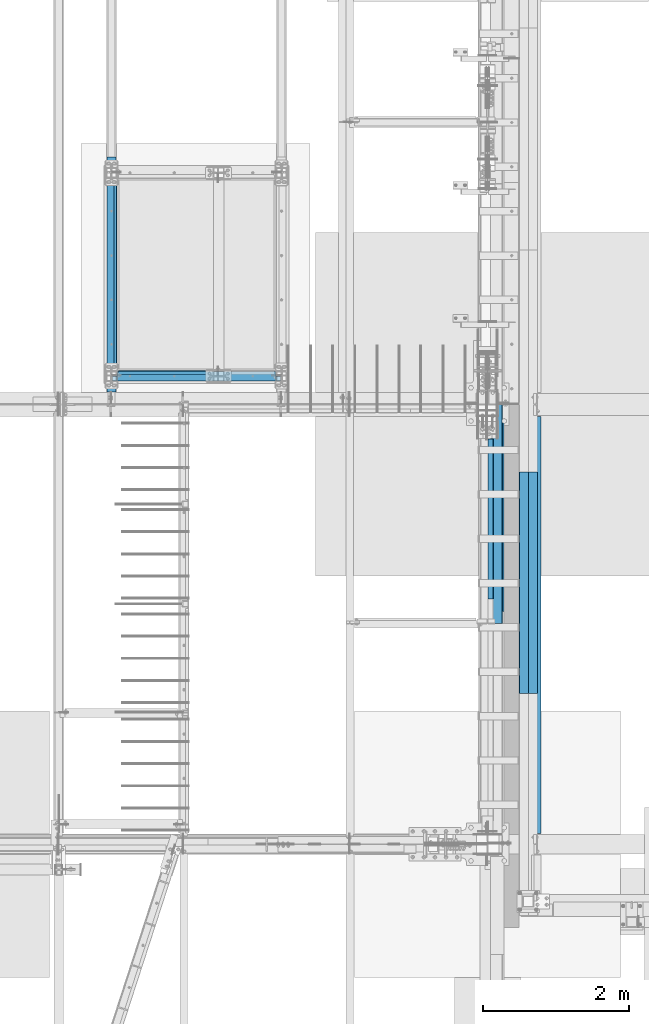
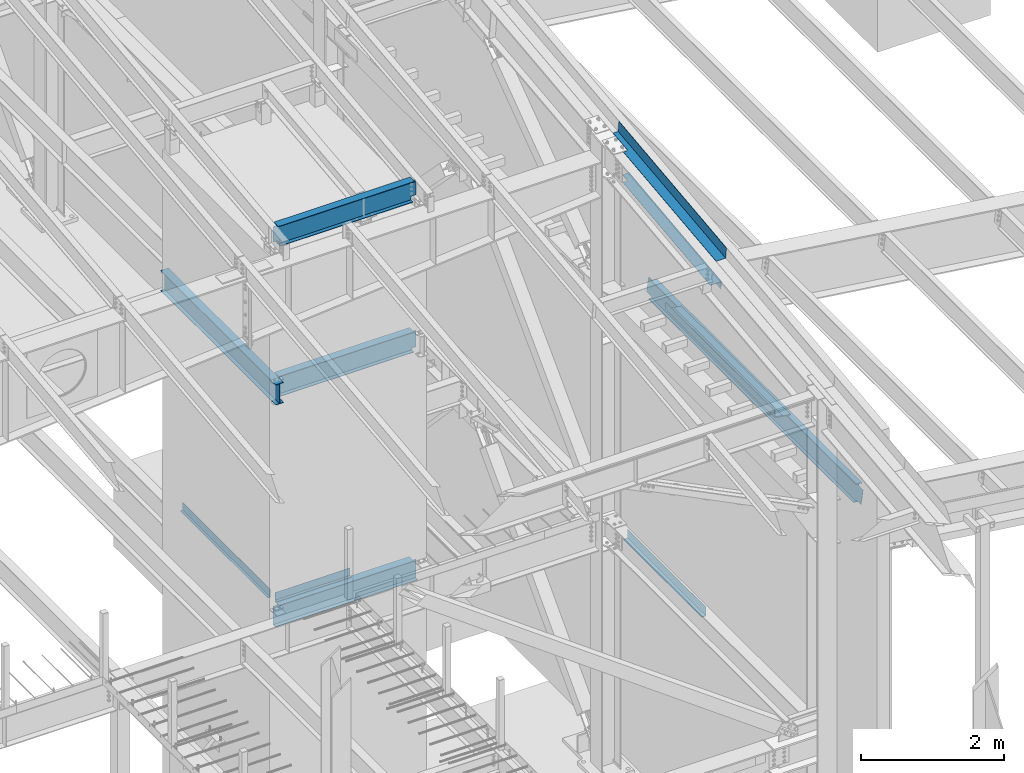
# One storey, part 721 of 1179: 12 beams, 10 elements without a shape of their own.
"""IFC2X3 building model written with IfcOpenShell, lengths in millimetres."""

from ifc_helpers import new_model, si_unit, frame, origin_with_axes, place, context, subcontext, project, spatial, faceted_brep, material, type_object, element, aggregate, save


model = new_model("IFC2X3")

# Units and contexts
model_context = context("Model", 3, precision=1e-05, world=origin_with_axes())
body_context = subcontext(model_context, "Body", "Model", "MODEL_VIEW")
ifc_project = project(units=[si_unit("LENGTHUNIT", "METRE", prefix="MILLI"), si_unit("AREAUNIT", "SQUARE_METRE"), si_unit("VOLUMEUNIT", "CUBIC_METRE"), si_unit("MASSUNIT", "GRAM", prefix="KILO"), si_unit("TIMEUNIT", "SECOND"), si_unit("PLANEANGLEUNIT", "RADIAN"), si_unit("SOLIDANGLEUNIT", "STERADIAN"), si_unit("THERMODYNAMICTEMPERATUREUNIT", "DEGREE_CELSIUS"), si_unit("LUMINOUSINTENSITYUNIT", "LUMEN")], contexts=[model_context])

# Site, building, storey
site_placement = place(None, origin_with_axes())
site = spatial("IfcSite", under=ifc_project, at=site_placement, CompositionType="ELEMENT")
building_placement = place(site_placement, origin_with_axes())
building = spatial("IfcBuilding", under=site, at=building_placement, Name="Undefined", CompositionType="ELEMENT")
storey_placement = place(building_placement, origin_with_axes())
storey = spatial("IfcBuildingStorey", under=building, at=storey_placement, Name="Undefined", CompositionType="ELEMENT", Elevation=0.0)

# Assembly, beam
assembly_1_placement = place(storey_placement, origin_with_axes())
assembly_1 = element("IfcElementAssembly", 1, at=assembly_1_placement, inside=storey, Name="BEAM", AssemblyPlace="NOTDEFINED", PredefinedType="RIGID_FRAME")
ifc_material_1 = material(Name="STEEL/A36")
beam_type_1 = type_object("IfcBeamType", PredefinedType="NOTDEFINED")
beam_1_placement = place(assembly_1_placement, frame((19837.4000030518, 11941.1750007629, 4235.45000610352), z_axis=(1.0, 0.0, 0.0), x_axis=(0.0, 0.0, -1.0)))
beam_1 = element("IfcBeam", 2, at=beam_1_placement, type_object=beam_type_1, material=ifc_material_1, Name="BENT_PLATE", context=body_context, shape_type="Brep", body=[
    faceted_brep([(0.0, -3.17499999999927, -603.25), (0.0, -3.17499999999927, 603.25), (0.0, 3.17499999999927, 603.25), (0.0, 3.17499999999927, -603.25), (133.350006103517, 3.17499999999927, 603.25), (133.350006103517, 3.17499999999927, -603.25), (127.000006103516, -3.17499999999927, -603.25), (127.000006103516, -3.17499999999927, 603.25), (133.350006103517, -47.6250007629405, 603.25), (133.350006103517, -47.6250007629405, -603.25), (127.000006103516, -47.6250007629405, 603.25), (127.000006103516, -47.6250007629405, -603.25)], [[[0, 1, 2, 3]], [[3, 2, 4, 5]], [[1, 0, 6, 7]], [[5, 4, 8, 9]], [[4, 2, 1, 7, 10, 8]], [[7, 6, 11, 10]], [[6, 0, 3, 5, 9, 11]], [[10, 11, 9, 8]]]),
])

assembly_2_placement = place(storey_placement, origin_with_axes())
assembly_2 = element("IfcElementAssembly", 3, at=assembly_2_placement, inside=storey, Name="BEAM", AssemblyPlace="NOTDEFINED", PredefinedType="RIGID_FRAME")
ifc_material_2 = material(Name="STEEL/A992")
beam_type_2 = type_object("IfcBeamType", Name="W14X22", PredefinedType="NOTDEFINED")
beam_2_placement = place(assembly_2_placement, frame((19138.9, 11868.1499999452, 10406.1649228246), z_axis=(0.0, 0.0, 1.0), x_axis=(1.0, 0.0, 0.0)))
beam_2 = element("IfcBeam", 4, at=beam_2_placement, type_object=beam_type_2, material=ifc_material_2, Name="BEAM", ObjectType="W14X22", context=body_context, shape_type="Brep", body=[
    faceted_brep([(2244.725, -3.17499999999927, -166.6875), (2244.725, -63.5, -166.6875), (2244.725, -63.5, -174.625), (2244.725, 63.5, -174.625), (2244.725, 63.5, -166.6875), (2244.725, 3.17499999999927, -166.6875), (2244.725, 3.17499999999927, -123.824999806495), (2244.725, -3.17499999999927, -123.824999806495), (2245.69172992259, 3.17499999999927, -118.964920288448), (2245.69172992259, -3.17499999999927, -118.964920288448), (2248.44474382306, 3.17499999999927, -114.844743820295), (2248.44474382306, -3.17499999999927, -114.844743820295), (2252.56492029122, 3.17499999999927, -112.091729919817), (2252.56492029122, -3.17499999999927, -112.091729919817), (2257.42499980926, 3.17499999999927, -111.12499999723), (2257.42499980926, -3.17499999999927, -111.12499999723), (2320.925, -3.17499999999927, -111.12499999723), (2320.925, 3.17499999999927, -111.12499999723), (66.6749999999993, 3.17499999999927, 166.6875), (66.6749999999993, 63.5, 166.6875), (2270.125, 63.5, 166.6875), (2270.125, 3.17499999999927, 166.6875), (92.0750000000007, -3.17499999999927, -123.824999806491), (92.0750000000007, 3.17499999999927, -123.824999806491), (92.0750000000007, 3.17499999999927, -166.6875), (92.0750000000007, 63.5, -166.6875), (92.0750000000007, 63.5, -174.625), (92.0750000000007, -63.5, -174.625), (92.0750000000007, -63.5, -166.6875), (92.0750000000007, -3.17499999999927, -166.6875), (91.1082700774132, -3.17499999999927, -118.964920288445), (91.1082700774132, 3.17499999999927, -118.964920288445), (88.3552561769357, -3.17499999999927, -114.844743820291), (88.3552561769357, 3.17499999999927, -114.844743820291), (84.235079708782, -3.17499999999927, -112.091729919814), (84.235079708782, 3.17499999999927, -112.091729919814), (79.3750001907356, -3.17499999999927, -111.124999997226), (79.3750001907356, 3.17499999999927, -111.124999997226), (15.875, -3.17499999999927, -111.124999997226), (15.875, 3.17499999999927, -111.124999997226), (15.875, -3.17499999999927, 149.225000002774), (15.875, 3.17499999999927, 149.225000002774), (53.9750001907341, -3.17499999999927, 149.225000002774), (53.9750001907341, 3.17499999999927, 149.225000002774), (58.8350797087805, -3.17499999999927, 150.191729925362), (58.8350797087805, 3.17499999999927, 150.191729925362), (62.9552561769342, -3.17499999999927, 152.944743825839), (62.9552561769342, 3.17499999999927, 152.944743825839), (65.7082700774117, -3.17499999999927, 157.064920293993), (65.7082700774117, 3.17499999999927, 157.064920293993), (66.6749999999993, -3.17499999999927, 161.924999812039), (66.6749999999993, 3.17499999999927, 161.924999812039), (66.6749999999993, -63.5, 174.625), (66.6749999999993, 63.5, 174.625), (66.6749999999993, -3.17499999999927, 166.6875), (66.6749999999993, -63.5, 166.6875), (2270.125, -3.17499999999927, 166.6875), (2270.125, -63.5, 166.6875), (2270.125, -63.5, 174.625), (2270.125, 63.5, 174.625), (2270.125, -3.17499999999927, 161.924999812036), (2270.125, 3.17499999999927, 161.924999812036), (2271.09172992259, -3.17499999999927, 157.064920293989), (2271.09172992259, 3.17499999999927, 157.064920293989), (2273.84474382307, -3.17499999999927, 152.944743825836), (2273.84474382307, 3.17499999999927, 152.944743825836), (2277.96492029122, -3.17499999999927, 150.191729925358), (2277.96492029122, 3.17499999999927, 150.191729925358), (2282.82499980927, -3.17499999999927, 149.225000002771), (2282.82499980927, 3.17499999999927, 149.225000002771), (2320.925, -3.17499999999927, 149.225000002771), (2320.925, 3.17499999999927, 149.225000002771)], [[[0, 1, 2, 3, 4, 5, 6, 7]], [[7, 6, 8, 9]], [[9, 8, 10, 11]], [[11, 10, 12, 13]], [[13, 12, 14, 15]], [[16, 15, 14, 17]], [[18, 19, 20, 21]], [[22, 23, 24, 25, 26, 27, 28, 29]], [[30, 31, 23, 22]], [[32, 33, 31, 30]], [[34, 35, 33, 32]], [[36, 37, 35, 34]], [[38, 39, 37, 36]], [[40, 41, 39, 38]], [[42, 43, 41, 40]], [[44, 45, 43, 42]], [[46, 47, 45, 44]], [[48, 49, 47, 46]], [[50, 51, 49, 48]], [[52, 53, 19, 18, 51, 50, 54, 55]], [[55, 54, 56, 57]], [[52, 55, 57, 58]], [[53, 52, 58, 59]], [[19, 53, 59, 20]], [[58, 57, 56, 60, 61, 21, 20, 59]], [[62, 63, 61, 60]], [[64, 65, 63, 62]], [[66, 67, 65, 64]], [[68, 69, 67, 66]], [[70, 71, 69, 68]], [[71, 70, 16, 17]], [[12, 10, 8, 6, 5, 24, 23, 31, 33, 35, 37, 39, 41, 43, 45, 47, 49, 51, 18, 21, 61, 63, 65, 67, 69, 71, 17, 14]], [[25, 24, 5, 4]], [[26, 25, 4, 3]], [[27, 26, 3, 2]], [[28, 27, 2, 1]], [[29, 28, 1, 0]], [[70, 68, 66, 64, 62, 60, 56, 54, 50, 48, 46, 44, 42, 40, 38, 36, 34, 32, 30, 22, 29, 0, 7, 9, 11, 13, 15, 16]]]),
])
aggregate(assembly_2, [beam_2])

assembly_3_placement = place(storey_placement, origin_with_axes())
assembly_3 = element("IfcElementAssembly", 5, at=assembly_3_placement, inside=storey, Name="BEAM", AssemblyPlace="NOTDEFINED", PredefinedType="RIGID_FRAME")
beam_3_placement = place(assembly_3_placement, frame((19138.9, 11652.2500015259, 7839.075), z_axis=(0.0, 0.0, 1.0), x_axis=(0.0, 1.0, 0.0)))
beam_3 = element("IfcBeam", 6, at=beam_3_placement, type_object=beam_type_2, material=ifc_material_2, Name="BEAM", ObjectType="W14X22", context=body_context, shape_type="Brep", body=[
    faceted_brep([(0.0, 63.5, -174.625), (0.0, 63.5, -166.6875), (3225.79999694824, 63.5, -166.6875), (3225.79999694824, 63.5, -174.625), (-1.21872290037572e-10, 3.17500000000018, -166.687500000036), (3225.79999694824, 3.17499999999927, -166.6875), (1.20053300634027e-10, 3.17500000000018, 166.687500000036), (3225.79999694824, 3.17499999999927, 166.6875), (0.0, 63.5, 166.6875), (3225.79999694824, 63.5, 166.6875), (0.0, 63.5, 174.625), (3225.79999694824, 63.5, 174.625), (0.0, -63.5, 174.625), (3225.79999694824, -63.5, 174.625), (0.0, -63.5, 166.6875), (3225.79999694824, -63.5, 166.6875), (1.20053300634027e-10, -3.17500000000018, 166.687500000036), (3225.79999694824, -3.17499999999927, 166.6875), (-1.21872290037572e-10, -3.17500000000018, -166.687500000036), (3225.79999694824, -3.17499999999927, -166.6875), (0.0, -63.5, -166.6875), (3225.79999694824, -63.5, -166.6875), (0.0, -63.5, -174.625), (3225.79999694824, -63.5, -174.625)], [[[0, 1, 2, 3]], [[1, 4, 5, 2]], [[4, 6, 7, 5]], [[6, 8, 9, 7]], [[8, 10, 11, 9]], [[10, 12, 13, 11]], [[12, 14, 15, 13]], [[14, 16, 17, 15]], [[16, 18, 19, 17]], [[18, 20, 21, 19]], [[20, 22, 23, 21]], [[22, 0, 3, 23]], [[5, 7, 9, 11, 13, 15, 17, 19, 21, 23, 3, 2]], [[22, 20, 18, 16, 14, 12, 10, 8, 6, 4, 1, 0]]]),
])
aggregate(assembly_3, [beam_3])

assembly_4_placement = place(storey_placement, origin_with_axes())
assembly_4 = element("IfcElementAssembly", 7, at=assembly_4_placement, inside=storey, Name="BEAM", AssemblyPlace="NOTDEFINED", PredefinedType="RIGID_FRAME")
beam_4_placement = place(assembly_4_placement, frame((19138.9, 11868.15, 7839.075), z_axis=(0.0, 0.0, 1.0), x_axis=(1.0, 0.0, 0.0)))
beam_4 = element("IfcBeam", 8, at=beam_4_placement, type_object=beam_type_2, material=ifc_material_2, Name="BEAM", ObjectType="W14X22", context=body_context, shape_type="Brep", body=[
    faceted_brep([(2257.42499999999, -3.17499999999927, -166.6875), (2257.42499999999, -63.5, -166.6875), (2257.42499999999, -63.5, -174.625), (2257.42499999999, 63.5, -174.625), (2257.42499999999, 63.5, -166.6875), (2257.42499999999, 3.17499999999927, -166.6875), (2257.42499999999, 3.17499999999927, -155.574999809265), (2257.42499999999, -3.17499999999927, -155.574999809265), (2258.39172992258, 3.17499999999927, -150.71492029122), (2258.39172992258, -3.17499999999927, -150.71492029122), (2261.14474382306, 3.17499999999927, -146.594743823066), (2261.14474382306, -3.17499999999927, -146.594743823066), (2265.26492029121, 3.17499999999927, -143.841729922588), (2265.26492029121, -3.17499999999927, -143.841729922588), (2270.12499980926, 3.17499999999927, -142.875), (2270.12499980926, -3.17499999999927, -142.875), (2320.925, -3.17499999999927, -142.875), (2320.925, 3.17499999999927, -142.875), (76.2000000000007, 3.17499999999927, 166.6875), (76.2000000000007, 63.5, 166.6875), (2260.59999999999, 63.5, 166.6875), (2260.59999999999, 3.17499999999927, 166.6875), (79.375, -3.17499999999927, -155.574999809265), (79.375, 3.17499999999927, -155.574999809265), (79.375, 3.17499999999927, -166.6875), (79.375, 63.5, -166.6875), (79.375, 63.5, -174.625), (79.375, -63.5, -174.625), (79.375, -63.5, -166.6875), (79.375, -3.17499999999927, -166.6875), (78.4082700774125, -3.17499999999927, -150.71492029122), (78.4082700774125, 3.17499999999927, -150.71492029122), (75.6552561769349, -3.17499999999927, -146.594743823066), (75.6552561769349, 3.17499999999927, -146.594743823066), (71.5350797087813, -3.17499999999927, -143.841729922588), (71.5350797087813, 3.17499999999927, -143.841729922588), (66.6750001907349, -3.17499999999927, -142.875), (66.6750001907349, 3.17499999999927, -142.875), (15.8749999999964, -3.17499999999927, -142.875), (15.8749999999964, 3.17499999999927, -142.875), (15.8750000000018, -3.17500000000291, 142.874999999998), (15.8750000000018, 3.17500000000291, 142.874999999998), (63.5, -3.17499999993015, 142.874999807531), (63.5, 3.1750000039101, 142.874999807529), (68.360079708782, -3.17499999999927, 143.841729922588), (68.360079708782, 3.17499999999927, 143.841729922588), (72.4802561769357, -3.17499999999927, 146.594743823066), (72.4802561769357, 3.17499999999927, 146.594743823066), (75.2332700774132, -3.17499999999927, 150.71492029122), (75.2332700774132, 3.17499999999927, 150.71492029122), (76.2000000000007, -3.17499999999927, 155.574999809265), (76.2000000000007, 3.17499999999927, 155.574999809265), (76.2000000000007, -63.5, 174.625), (76.2000000000007, 63.5, 174.625), (76.2000000000007, -3.17499999999927, 166.6875), (76.2000000000007, -63.5, 166.6875), (2260.59999999999, -3.17499999999927, 166.6875), (2260.59999999999, -63.5, 166.6875), (2260.59999999999, -63.5, 174.625), (2260.59999999999, 63.5, 174.625), (2260.59999999999, -3.17499999999927, 155.574999809265), (2260.59999999999, 3.17499999999927, 155.574999809265), (2261.56672992258, -3.17499999999927, 150.71492029122), (2261.56672992258, 3.17499999999927, 150.71492029122), (2264.31974382306, -3.17499999999927, 146.594743823066), (2264.31974382306, 3.17499999999927, 146.594743823066), (2268.43992029121, -3.17499999999927, 143.841729922588), (2268.43992029121, 3.17499999999927, 143.841729922588), (2273.29999980926, -3.17499999999927, 142.875), (2273.29999980926, 3.17499999999927, 142.875), (2320.925, -3.17499999999927, 142.875), (2320.925, 3.17499999999927, 142.875)], [[[0, 1, 2, 3, 4, 5, 6, 7]], [[7, 6, 8, 9]], [[9, 8, 10, 11]], [[11, 10, 12, 13]], [[13, 12, 14, 15]], [[16, 15, 14, 17]], [[18, 19, 20, 21]], [[22, 23, 24, 25, 26, 27, 28, 29]], [[30, 31, 23, 22]], [[32, 33, 31, 30]], [[34, 35, 33, 32]], [[36, 37, 35, 34]], [[38, 39, 37, 36]], [[40, 41, 39, 38]], [[42, 43, 41, 40]], [[44, 45, 43, 42]], [[46, 47, 45, 44]], [[48, 49, 47, 46]], [[50, 51, 49, 48]], [[52, 53, 19, 18, 51, 50, 54, 55]], [[55, 54, 56, 57]], [[52, 55, 57, 58]], [[53, 52, 58, 59]], [[19, 53, 59, 20]], [[58, 57, 56, 60, 61, 21, 20, 59]], [[62, 63, 61, 60]], [[64, 65, 63, 62]], [[66, 67, 65, 64]], [[68, 69, 67, 66]], [[70, 71, 69, 68]], [[71, 70, 16, 17]], [[12, 10, 8, 6, 5, 24, 23, 31, 33, 35, 37, 39, 41, 43, 45, 47, 49, 51, 18, 21, 61, 63, 65, 67, 69, 71, 17, 14]], [[25, 24, 5, 4]], [[26, 25, 4, 3]], [[27, 26, 3, 2]], [[28, 27, 2, 1]], [[29, 28, 1, 0]], [[70, 68, 66, 64, 62, 60, 56, 54, 50, 48, 46, 44, 42, 40, 38, 36, 34, 32, 30, 22, 29, 0, 7, 9, 11, 13, 15, 16]]]),
])
aggregate(assembly_4, [beam_4])

# Beam
beam_5_placement = place(assembly_1_placement, frame((19138.9, 11868.15, 3927.475), z_axis=(0.0, 0.0, 1.0), x_axis=(1.0, 0.0, 0.0)))
beam_5 = element("IfcBeam", 9, at=beam_5_placement, type_object=beam_type_2, material=ifc_material_2, Name="BEAM", ObjectType="W14X22", context=body_context, shape_type="Brep", body=[
    faceted_brep([(2254.25, -63.5, 174.625), (2254.25, -63.5, 166.6875), (2254.25, -3.17499999999927, 166.6875), (2254.25, -3.17499999999927, 155.574999809265), (2254.25, 3.17495510407934, 155.574999809265), (2254.25, 3.17499999999927, 166.6875), (2254.25, 63.5, 166.6875), (2254.25, 63.5, 174.625), (2255.21672992259, -3.17499999999927, 150.71492029122), (2255.21672992259, 3.17495876243083, 150.71492029122), (2257.96974382307, -3.17499999999927, 146.594743823066), (2257.96974382307, 3.17496186523749, 146.594743823066), (2262.08992029122, -3.17499999999927, 143.841729922588), (2262.08992029122, 3.17496394012414, 143.841729922588), (2266.94999980927, -3.17499999999927, 142.875), (2266.94999980927, 3.17496467120691, 142.875), (2320.925, -3.17499999999927, 142.875), (2320.925, 3.17499999999927, 142.875), (82.5499999999993, -63.5, 174.625), (82.5499999999993, 63.5, 174.625), (82.5499999999993, 63.5, 166.6875), (82.5499999999993, 3.17500000000291, 166.6875), (82.5499999999993, 3.17496616959397, 155.574999809263), (82.5499999999993, -3.17500000000291, 155.574999809263), (82.5499999999993, -3.17500000000291, 166.6875), (82.5499999999993, -63.5, 166.6875), (81.5832700774117, 3.17496981359, 150.714920291217), (81.5832700774117, -3.17500000000291, 150.714920291217), (78.8302561769342, 3.17497290281608, 146.594743823063), (78.8302561769342, -3.17500000000291, 146.594743823063), (74.7100797087805, 3.17497496696888, 143.841729922586), (74.7100797087805, -3.17500000000291, 143.841729922586), (69.8500001907341, 3.17497569180705, 142.874999999998), (69.8500001907341, -3.17500000000291, 142.874999999998), (15.8750000000018, 3.17500000000291, 142.874999999998), (15.8750000000018, -3.17500000000291, 142.874999999998), (15.8750000000018, 3.17500000000291, -166.6875), (15.8750000000018, 3.17549991607666, -174.625), (15.8750000000018, -63.5, -174.625), (15.8750000000018, -63.5, -166.6875), (15.8750000000018, -3.17500000000291, -166.6875), (142.875000000002, 3.17549991607666, -166.6875), (142.875000000002, 3.17549991607666, -174.625), (142.875000000002, 63.5, -166.6875), (142.875000000002, 63.5, -174.625), (2193.92499999986, 3.17502914962461, -166.6875), (2193.925, 63.5, -166.6875), (2193.925, 63.5, -174.625), (2193.925, 3.17561880122958, -174.625), (2320.925, 3.17499999999927, -166.6875), (2320.925, 3.17561880122958, -174.625), (2320.925, -63.5, -174.625), (2320.925, -63.5, -166.6875), (2320.925, -3.17499999999927, -166.6875)], [[[0, 1, 2, 3, 4, 5, 6, 7]], [[8, 9, 4, 3]], [[10, 11, 9, 8]], [[12, 13, 11, 10]], [[14, 15, 13, 12]], [[16, 17, 15, 14]], [[18, 19, 20, 21, 22, 23, 24, 25]], [[23, 22, 26, 27]], [[27, 26, 28, 29]], [[29, 28, 30, 31]], [[31, 30, 32, 33]], [[33, 32, 34, 35]], [[36, 37, 38, 39, 40, 35, 34]], [[41, 42, 37, 36]], [[43, 44, 42, 41]], [[43, 41, 45, 46]], [[44, 43, 46, 47]], [[45, 48, 47, 46]], [[49, 50, 48, 45]], [[51, 38, 37, 42, 44, 47, 48, 50]], [[39, 38, 51, 52]], [[40, 39, 52, 53]], [[12, 10, 8, 3, 2, 24, 23, 27, 29, 31, 33, 35, 40, 53, 16, 14]], [[25, 24, 2, 1]], [[18, 25, 1, 0]], [[19, 18, 0, 7]], [[20, 19, 7, 6]], [[21, 20, 6, 5]], [[49, 45, 41, 36, 34, 32, 30, 28, 26, 22, 21, 5, 4, 9, 11, 13, 15, 17]], [[53, 52, 51, 50, 49, 17, 16]]]),
])

aggregate(assembly_1, [beam_1, beam_5])

# Assembly, beam
assembly_5_placement = place(storey_placement, origin_with_axes())
assembly_5 = element("IfcElementAssembly", 10, at=assembly_5_placement, inside=storey, Name="BEAM", AssemblyPlace="NOTDEFINED", PredefinedType="RIGID_FRAME")
beam_type_3 = type_object("IfcBeamType", PredefinedType="NOTDEFINED")
beam_6_placement = place(assembly_5_placement, frame((19170.65, 13265.149512207, 4105.275), z_axis=(0.0, -1.0, 0.0), x_axis=(1.0, 0.0, 0.0)))
beam_6 = element("IfcBeam", 11, at=beam_6_placement, type_object=beam_type_3, material=ifc_material_1, Name="BENT_PLATE", context=body_context, shape_type="Brep", body=[
    faceted_brep([(-2.00088834390044e-10, -3.17500000000018, -1225.55), (2.05545802600682e-10, -3.17500000000018, 1225.55), (2.05545802600682e-10, 3.17500000000018, 1225.55), (-2.00088834390044e-10, 3.17500000000018, -1225.55), (38.0999999996566, 3.17500000000018, 1225.55000000001), (38.1000000004224, 3.17500000000018, -1225.55), (44.4500000004227, -3.17500000000018, -1225.55), (44.4499999996569, -3.17500000000018, 1225.55000000001), (38.0999999996602, 130.175006103443, 1225.55000000001), (38.1000000004187, 130.175006103512, -1225.54999999999), (44.4499999996606, 130.175006103443, 1225.55000000002), (44.4500000004191, 130.175006103512, -1225.54999999999)], [[[0, 1, 2, 3]], [[3, 2, 4, 5]], [[1, 0, 6, 7]], [[5, 4, 8, 9]], [[4, 2, 1, 7, 10, 8]], [[7, 6, 11, 10]], [[6, 0, 3, 5, 9, 11]], [[10, 11, 9, 8]]]),
])
aggregate(assembly_5, [beam_6])

assembly_6_placement = place(storey_placement, origin_with_axes())
assembly_6 = element("IfcElementAssembly", 12, at=assembly_6_placement, inside=storey, Name="BEAM", AssemblyPlace="NOTDEFINED", PredefinedType="RIGID_FRAME")
beam_type_4 = type_object("IfcBeamType", PredefinedType="NOTDEFINED")
beam_7_placement = place(assembly_6_placement, frame((24350.6630000631, 9972.15233490017, 10376.9153223565), z_axis=(0.0, -0.993676146336441, -0.112284087038017), x_axis=(1.0, 0.0, 0.0)))
beam_7 = element("IfcBeam", 13, at=beam_7_placement, type_object=beam_type_4, material=ifc_material_1, Name="BENT_PLATE", context=body_context, shape_type="Brep", body=[
    faceted_brep([(71.4348770426986, -3.17477152440551, -1098.72850955091), (71.4349112265518, 3.17499999955544, -1098.72851302124), (71.4353934272913, 3.17499999938627, -1515.26899999915), (71.4353592422158, -3.17500000060863, -1515.26899999915), (0.0, -3.17500000043947, -1098.728495279), (0.0, 3.17499999955726, -1098.72849874912), (153.986999996814, 3.17500000061409, 1515.26899999915), (0.0, 3.17500000061409, 1515.26899999915), (0.0, -3.17499999938082, 1515.26899999915), (160.336999996813, -3.17499999938082, 1515.26899999915), (160.336999996813, 187.324999996976, 1515.26899999907), (153.986999996814, 187.324999996976, 1515.26899999907), (153.986999996814, 3.17499999938627, -1515.26899999915), (153.986999996814, 187.324999995748, -1515.26899999923), (160.336999996813, 187.324999995748, -1515.26899999923), (160.336999996813, -3.17500000060863, -1515.26899999915)], [[[0, 1, 2, 3]], [[4, 5, 1, 0]], [[6, 7, 8, 9, 10, 11]], [[12, 6, 11, 13]], [[10, 14, 13, 11]], [[9, 15, 14, 10]], [[12, 13, 14, 15, 3, 2]], [[7, 6, 12, 2, 1, 5]], [[8, 7, 5, 4]], [[15, 9, 8, 4, 0, 3]]]),
])

assembly_7_placement = place(storey_placement, origin_with_axes())
assembly_7 = element("IfcElementAssembly", 14, at=assembly_7_placement, inside=storey, Name="BEAM", AssemblyPlace="NOTDEFINED", PredefinedType="RIGID_FRAME")
beam_type_5 = type_object("IfcBeamType", PredefinedType="NOTDEFINED")
beam_8_placement = place(assembly_7_placement, frame((24313.3562293837, 9904.41250372757, 3935.41250614813), z_axis=(0.0, 1.0, 0.0), x_axis=(1.0, 0.0, 0.0)))
beam_8 = element("IfcBeam", 15, at=beam_8_placement, type_object=beam_type_5, material=ifc_material_1, Name="BENT_PLATE", context=body_context, shape_type="Brep", body=[
    faceted_brep([(-2.79243295153719e-09, -3.17500000000018, -1098.55000000001), (8.76752892509103e-10, -3.17500000000064, 1098.55), (1.41881173476577e-10, 3.17499999999973, 1098.55), (-7.24725168765872e-10, 3.17500000000018, -1098.55000000001), (72.2312501533488, 3.17500000827476, 1098.5500000001), (72.2312501533124, 3.17500000827476, -1098.5499999999), (65.8812496135906, -3.17499999245274, -1098.54999999991), (65.881249613627, -3.17499999245274, 1098.55000000009), (72.2312372005836, -149.224999839358, 1098.55000000017), (72.2312371994558, -149.224999840357, -1098.54999999983), (65.881237200585, -149.224999299628, 1098.55000000016), (65.8812371994536, -149.224999300627, -1098.54999999984)], [[[0, 1, 2, 3]], [[3, 2, 4, 5]], [[1, 0, 6, 7]], [[5, 4, 8, 9]], [[4, 2, 1, 7, 10, 8]], [[7, 6, 11, 10]], [[6, 0, 3, 5, 9, 11]], [[10, 11, 9, 8]]]),
])
aggregate(assembly_7, [beam_8])

# Beam
beam_type_6 = type_object("IfcBeamType", PredefinedType="NOTDEFINED")
beam_9_placement = place(assembly_6_placement, frame((24350.6629996069, 9928.05389112538, 9843.12627939926), z_axis=(0.0, -0.993676146336441, -0.112284087038017), x_axis=(1.0, 0.0, 0.0)))
beam_9 = element("IfcBeam", 16, at=beam_9_placement, type_object=beam_type_6, material=ifc_material_1, Name="BENT_PLATE", context=body_context, shape_type="Brep", body=[
    faceted_brep([(76.1995003925476, -3.17611935710011, -1155.7000000263), (76.1995003925476, 3.17449425665109, -1155.70000002381), (76.1995003925476, 3.17499999946813, -1301.74999999927), (76.1995003925476, -3.1750000005286, -1301.74999999927), (0.0, -3.17500000046493, -1155.7000000263), (0.0, 3.17499999953179, -1155.70000002381), (185.73700039148, 3.17500000051587, 1301.74999999927), (0.0, 3.1750000005286, 1301.74999999927), (0.0, -3.17499999946813, 1301.74999999927), (179.387000391482, -3.17499999948086, 1301.74999999927), (179.387000391482, -136.52499960179, 1301.74999999933), (185.73700039148, -136.52499960179, 1301.74999999933), (185.73700039148, 3.17499999946085, -1301.74999999927), (185.73700039148, -136.524999602845, -1301.74999999922), (179.387000391482, -136.524999602845, -1301.74999999922), (179.387000391482, -3.17500000053406, -1301.74999999927)], [[[0, 1, 2, 3]], [[4, 5, 1, 0]], [[6, 7, 8, 9, 10, 11]], [[12, 6, 11, 13]], [[10, 14, 13, 11]], [[9, 15, 14, 10]], [[12, 13, 14, 15, 3, 2]], [[7, 6, 12, 2, 1, 5]], [[8, 7, 5, 4]], [[15, 9, 8, 4, 0, 3]]]),
])

aggregate(assembly_6, [beam_7, beam_9])

# Assembly, beam
assembly_8_placement = place(storey_placement, origin_with_axes())
assembly_8 = element("IfcElementAssembly", 17, at=assembly_8_placement, inside=storey, Name="PLATE", AssemblyPlace="NOTDEFINED", PredefinedType="RIGID_FRAME")
beam_type_7 = type_object("IfcBeamType", PredefinedType="NOTDEFINED")
beam_10_placement = place(assembly_8_placement, frame((24880.9652345644, 7505.69999999963, 7964.0487255808), z_axis=(-0.99100656978554, 0.0, 0.133813222971043), x_axis=(0.0, 1.0, 0.0)))
beam_10 = element("IfcBeam", 18, at=beam_10_placement, type_object=beam_type_7, material=ifc_material_1, Name="PLATE", context=body_context, shape_type="Brep", body=[
    faceted_brep([(0.0, 4.76249999999709, -114.3), (0.0, 4.76249999999709, 114.3), (3048.0, 4.76249999996799, 114.300000000025), (3048.0, 4.76250000002983, -114.300000000025), (0.0, -4.76249999999709, 114.3), (3048.0, -4.76250000003711, 114.300000000014), (0.0, -4.76249999999709, -114.3), (3048.0, -4.76249999997344, -114.300000000036)], [[[0, 1, 2, 3]], [[1, 4, 5, 2]], [[4, 6, 7, 5]], [[6, 0, 3, 7]], [[5, 7, 3, 2]], [[6, 4, 1, 0]]]),
])
aggregate(assembly_8, [beam_10])

assembly_9_placement = place(storey_placement, origin_with_axes())
assembly_9 = element("IfcElementAssembly", 19, at=assembly_9_placement, inside=storey, Name="BENT_PLATE", AssemblyPlace="NOTDEFINED", PredefinedType="RIGID_FRAME")
beam_type_8 = type_object("IfcBeamType", PredefinedType="NOTDEFINED")
beam_11_placement = place(assembly_9_placement, frame((24744.362499997, 9029.69999999963, 8102.29217706219), z_axis=(0.0, 1.0, 0.0), x_axis=(0.0, 0.0, -1.0)))
beam_11 = element("IfcBeam", 20, at=beam_11_placement, type_object=beam_type_8, material=ifc_material_1, Name="BENT_PLATE", context=body_context, shape_type="Brep", body=[
    faceted_brep([(-2.91038304567337e-11, -4.76250000000073, -1524.0), (-2.91038304567337e-11, -4.76250000000073, 1524.0), (2.91038304567337e-11, 4.76250000000073, 1524.0), (2.91038304567337e-11, 4.76250000000073, -1524.0), (114.300008765535, 4.76250001759399, 1524.0000000001), (114.300003051474, 4.7625000005828, -1524.0), (105.977955544956, -4.76249999945867, -1524.0), (105.977955544956, -4.76249999945867, 1524.0), (131.343048095475, -121.088742065571, 1524.0), (131.343048095475, -121.088742065571, -1524.0), (121.904205090902, -122.366970423507, 1524.0), (121.904205090902, -122.366970423507, -1524.0)], [[[0, 1, 2, 3]], [[3, 2, 4, 5]], [[1, 0, 6, 7]], [[5, 4, 8, 9]], [[4, 2, 1, 7, 10, 8]], [[7, 6, 11, 10]], [[6, 0, 3, 5, 9, 11]], [[10, 11, 9, 8]]]),
])
aggregate(assembly_9, [beam_11])

assembly_10_placement = place(storey_placement, origin_with_axes())
assembly_10 = element("IfcElementAssembly", 21, at=assembly_10_placement, inside=storey, Name="BEAM", AssemblyPlace="NOTDEFINED", PredefinedType="RIGID_FRAME")
beam_type_9 = type_object("IfcBeamType", Name="W12X22", PredefinedType="NOTDEFINED")
beam_12_placement = place(assembly_10_placement, frame((24972.7820076832, 5435.6, 7789.85835822108), z_axis=(0.133813223953133, 0.0, 0.991006569652931), x_axis=(0.0, 1.0, 0.0)))
beam_12 = element("IfcBeam", 22, at=beam_12_placement, type_object=beam_type_9, material=ifc_material_2, Name="BEAM", ObjectType="W12X22", context=body_context, shape_type="Brep", body=[
    faceted_brep([(5880.09999999999, -3.17499999983193, -144.462500000051), (5880.09999999999, -50.7999999998428, -144.462500000063), (5880.09999999999, -50.7999999998283, -155.575000000068), (5880.09999999999, 50.8000000001921, -155.575000000041), (5880.09999999999, 50.8000000001848, -144.462500000036), (5880.09999999999, 3.17500000017026, -144.462500000049), (5880.09999999999, 3.17500000016298, -136.52499982221), (5880.09999999999, -3.17499999983556, -136.524999822204), (5881.06672992258, 3.17500000015571, -131.66492030416), (5881.06672992258, -3.17499999984648, -131.664920304156), (5883.81974382306, 3.17500000015207, -127.544743836002), (5883.81974382306, -3.17499999985012, -127.544743835997), (5887.93992029121, 3.17500000014843, -124.791729935519), (5887.93992029121, -3.17499999985375, -124.791729935516), (5892.79999980926, 3.17500000014843, -123.825000012932), (5892.79999980926, -3.17499999985375, -123.825000012926), (6024.5625, -3.17499999985375, -123.825000012823), (6024.5625, 3.17500000014479, -123.825000012814), (144.4625, 3.17499999983193, 144.462500000049), (144.4625, 50.7999999998428, 144.462500000061), (5880.09999999999, 50.7999999998428, 144.462500000061), (5880.09999999999, 3.17499999983193, 144.462500000049), (146.049999999999, -3.1749999998392, -136.524999805057), (146.049999999999, 3.17500000015934, -136.52499980506), (146.049999999999, 3.17500000017026, -144.462500000049), (146.049999999999, 50.8000000001848, -144.462500000036), (146.049999999999, 50.8000000001921, -155.575000000041), (146.049999999999, -50.7999999998283, -155.575000000068), (146.049999999999, -50.7999999998428, -144.462500000063), (146.049999999999, -3.17499999983193, -144.462500000051), (145.083270077412, -3.17499999984284, -131.664920287005), (145.083270077412, 3.17500000015571, -131.664920287008), (142.330256176933, -3.17499999985012, -127.544743818849), (142.330256176933, 3.17500000015207, -127.544743818851), (138.21007970878, -3.17499999985375, -124.791729918366), (138.21007970878, 3.17500000014479, -124.791729918372), (133.350000190734, -3.17499999985375, -123.824999995779), (133.350000190734, 3.17500000014843, -123.824999995781), (19.0500000000002, -3.17499999985375, -123.824999995893), (19.0500000000002, 3.17500000014843, -123.824999995886), (19.0500000000002, -3.17500000013752, 117.475000004351), (19.0500000000002, 3.17499999986467, 117.475000004359), (131.762500190734, -3.17500000013752, 117.47500000447), (131.762500190734, 3.17499999986467, 117.475000004464), (136.62257970878, -3.17500000013752, 118.441729927057), (136.62257970878, 3.17499999986103, 118.441729927054), (140.742756176934, -3.17500000014115, 121.194743827538), (140.742756176934, 3.17499999986103, 121.194743827535), (143.495770077412, -3.17500000014479, 125.314920295696), (143.495770077412, 3.17499999985375, 125.314920295692), (144.4625, -3.17500000015571, 130.174999813746), (144.4625, 3.17499999984648, 130.174999813742), (144.4625, -50.8000000001921, 155.575000000039), (144.4625, 50.7999999998283, 155.575000000066), (144.4625, -3.17500000016662, 144.462500000047), (144.4625, -50.8000000001812, 144.462500000034), (5880.09999999999, -3.17500000016662, 144.462500000047), (5880.09999999999, -50.8000000001812, 144.462500000034), (5880.09999999999, -50.8000000001921, 155.575000000039), (5880.09999999999, 50.7999999998283, 155.575000000066), (5880.09999999999, -3.17500000015207, 130.17499979644), (5880.09999999999, 3.17499999985012, 130.174999796436), (5881.06672992258, -3.17500000014843, 125.314920278392), (5881.06672992258, 3.17499999985012, 125.314920278386), (5883.81974382306, -3.17500000014479, 121.194743810232), (5883.81974382306, 3.17499999985739, 121.194743810229), (5887.93992029121, -3.17500000013752, 118.441729909751), (5887.93992029121, 3.17499999986103, 118.441729909748), (5892.79999980926, -3.17500000013752, 117.474999987164), (5892.79999980926, 3.17499999986467, 117.474999987158), (6024.5625, -3.17500000013752, 117.474999987267), (6024.5625, 3.17499999986467, 117.474999987275)], [[[0, 1, 2, 3, 4, 5, 6, 7]], [[7, 6, 8, 9]], [[9, 8, 10, 11]], [[11, 10, 12, 13]], [[13, 12, 14, 15]], [[16, 15, 14, 17]], [[18, 19, 20, 21]], [[22, 23, 24, 25, 26, 27, 28, 29]], [[30, 31, 23, 22]], [[32, 33, 31, 30]], [[34, 35, 33, 32]], [[36, 37, 35, 34]], [[38, 39, 37, 36]], [[40, 41, 39, 38]], [[42, 43, 41, 40]], [[44, 45, 43, 42]], [[46, 47, 45, 44]], [[48, 49, 47, 46]], [[50, 51, 49, 48]], [[52, 53, 19, 18, 51, 50, 54, 55]], [[55, 54, 56, 57]], [[52, 55, 57, 58]], [[53, 52, 58, 59]], [[19, 53, 59, 20]], [[58, 57, 56, 60, 61, 21, 20, 59]], [[62, 63, 61, 60]], [[64, 65, 63, 62]], [[66, 67, 65, 64]], [[68, 69, 67, 66]], [[70, 71, 69, 68]], [[71, 70, 16, 17]], [[12, 10, 8, 6, 5, 24, 23, 31, 33, 35, 37, 39, 41, 43, 45, 47, 49, 51, 18, 21, 61, 63, 65, 67, 69, 71, 17, 14]], [[25, 24, 5, 4]], [[26, 25, 4, 3]], [[27, 26, 3, 2]], [[28, 27, 2, 1]], [[29, 28, 1, 0]], [[70, 68, 66, 64, 62, 60, 56, 54, 50, 48, 46, 44, 42, 40, 38, 36, 34, 32, 30, 22, 29, 0, 7, 9, 11, 13, 15, 16]]]),
])
aggregate(assembly_10, [beam_12])

save(model, "model.ifc")
